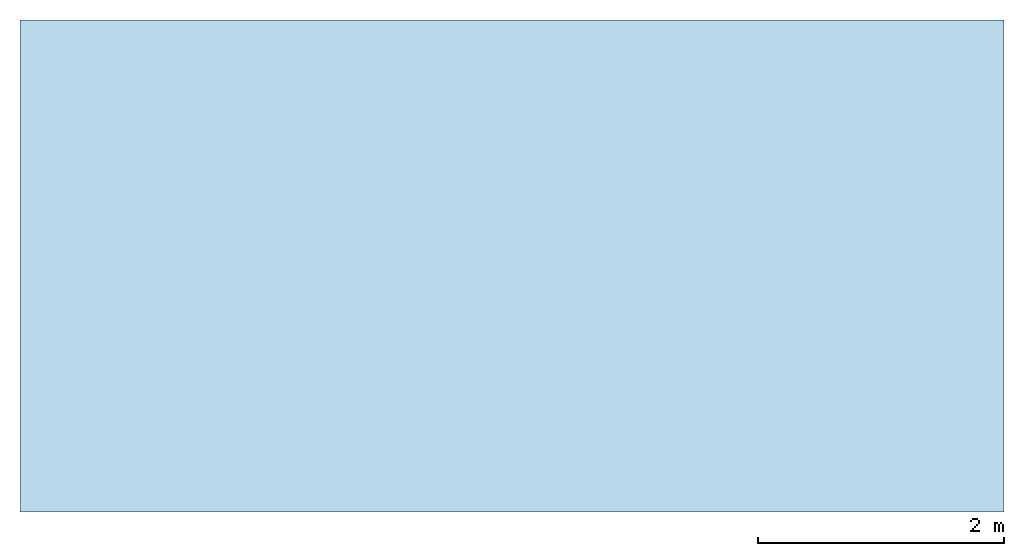
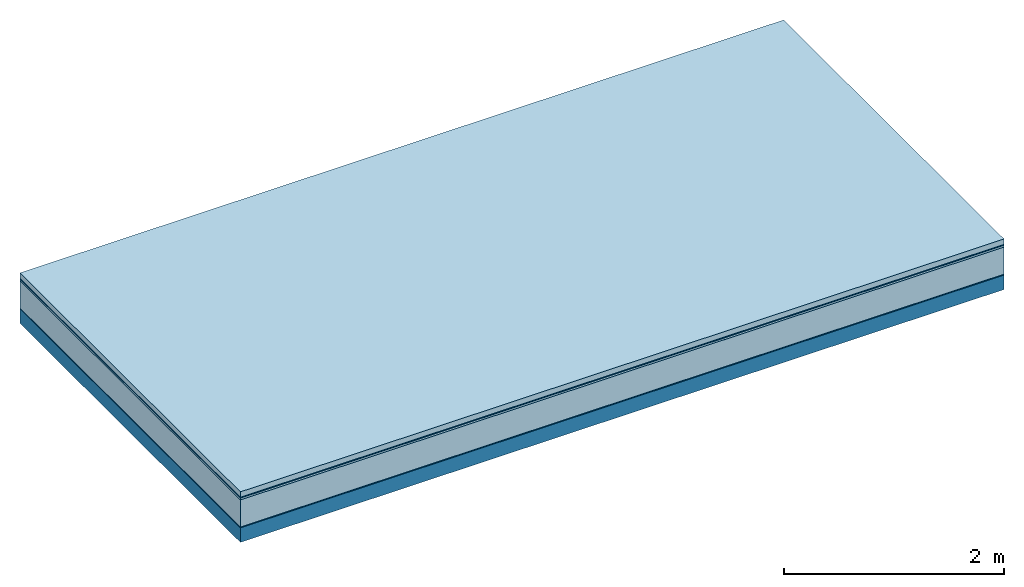
# One storey: 5 plates, 1 member, 1 element without a shape of its own.
"""IFC4 building model written with IfcOpenShell, lengths in metres."""

from ifc_helpers import new_model, si_unit, derived_unit, direction, frame, frame_2d, origin, origin_with_axes, place, context, project, spatial, rectangle, extrude, material, layer, layer_set, type_object, element, aggregate, save


model = new_model("IFC4")

# Units and contexts
plan_context = context("Plan", 3, precision=1e-05, world=origin(), true_north=direction((0.0, 1.0)))
model_context = context("Model", 3, precision=1e-05, world=origin(), true_north=direction((0.0, 1.0)))
ifc_project = project(units=[si_unit("LENGTHUNIT", "METRE"), derived_unit("SOUNDPRESSUREUNIT", [(si_unit("PRESSUREUNIT", "PASCAL", prefix="MICRO"), 0)]), si_unit("ENERGYUNIT", "JOULE", prefix="MEGA"), si_unit("MASSUNIT", "GRAM", prefix="KILO"), derived_unit("THERMALTRANSMITTANCEUNIT", [(si_unit("POWERUNIT", "WATT"), 1), (si_unit("AREAUNIT", "SQUARE_METRE"), -1), (si_unit("THERMODYNAMICTEMPERATUREUNIT", "KELVIN"), -1)]), derived_unit("AREADENSITYUNIT", [(si_unit("MASSUNIT", "GRAM", prefix="KILO"), 1), (si_unit("AREAUNIT", "SQUARE_METRE"), -1)]), derived_unit("USERDEFINED", [(si_unit("ENERGYUNIT", "JOULE", prefix="MEGA"), 1), (si_unit("AREAUNIT", "SQUARE_METRE"), -1)])], contexts=[plan_context, model_context])

# Site, building, storey
site = spatial("IfcSite", under=ifc_project)
building_placement = place(None, origin())
building = spatial("IfcBuilding", under=site, at=building_placement)
storey_placement = place(building_placement, origin())
storey = spatial("IfcBuildingStorey", under=building, at=storey_placement)

# Slab, member, plates
ifc_material_1 = material(Name="clay", Category="02.004")
ifc_layer_1 = layer(ifc_material_1, 0.06, Name="Use and protection layer 2")
ifc_material_2 = material(Name="Protective layer", Category="09.007")
ifc_layer_2 = layer(ifc_material_2, 0.01, Name="Use and protection layer 1")
ifc_material_3 = material(Name="Bituminous", Category="09.003")
ifc_layer_3 = layer(ifc_material_3, 0.02, Name="Seal")
ifc_material_4 = material(Name="Mineral wool", Category="10.008")
ifc_layer_4 = layer(ifc_material_4, 0.3, Name="Exterior insulation layer 1")
ifc_material_5 = material(Name="Vapor-permeable barrier", Category="09.006")
ifc_layer_5 = layer(ifc_material_5, 0.01, Name="layer / temporary roof")
ifc_material_6 = material(Name="no composite action")
ifc_layer_6 = layer(ifc_material_6, 0.0, Name="Bond")
ifc_layer_7 = layer(None, 0.16, Name="Support")
ifc_layer_set = layer_set([ifc_layer_1, ifc_layer_2, ifc_layer_3, ifc_layer_4, ifc_layer_5, ifc_layer_6, ifc_layer_7])
slab_type = type_object("IfcSlabType", Name="F0057", PredefinedType="NOTDEFINED", material=ifc_layer_set)
slab_placement = place(None, frame((0.0, 0.0, 0.0), z_axis=(0.0, 0.0, -1.0), x_axis=(1.0, 0.0, 0.0)))
slab = element("IfcSlab", 1, at=slab_placement, inside=storey, type_object=slab_type, material=ifc_layer_set, Name="Slab #1")
ifc_material_7 = material(Name="Solid timber panel")
member_placement = place(slab_placement, origin())
member = element("IfcMember", 2, at=member_placement, material=ifc_material_7, Name="Support", context=plan_context, shape_type="SweptSolid", body=[
    extrude(rectangle(XDim=1.0, YDim=0.16, at=frame_2d((0.5, 0.08), x_axis=(1.0, 0.0))), frame((0.0, 4.0, 0.4), z_axis=(0.0, -1.0, 0.0), x_axis=(1.0, 0.0, 0.0)), (0.0, 0.0, 1.0), 4.0),
    extrude(rectangle(XDim=1.0, YDim=0.16, at=frame_2d((0.5, 0.08), x_axis=(1.0, 0.0))), frame((1.0, 4.0, 0.4), z_axis=(0.0, -1.0, 0.0), x_axis=(1.0, 0.0, 0.0)), (0.0, 0.0, 1.0), 4.0),
    extrude(rectangle(XDim=1.0, YDim=0.16, at=frame_2d((0.5, 0.08), x_axis=(1.0, 0.0))), frame((2.0, 4.0, 0.4), z_axis=(0.0, -1.0, 0.0), x_axis=(1.0, 0.0, 0.0)), (0.0, 0.0, 1.0), 4.0),
    extrude(rectangle(XDim=1.0, YDim=0.16, at=frame_2d((0.5, 0.08), x_axis=(1.0, 0.0))), frame((3.0, 4.0, 0.4), z_axis=(0.0, -1.0, 0.0), x_axis=(1.0, 0.0, 0.0)), (0.0, 0.0, 1.0), 4.0),
    extrude(rectangle(XDim=1.0, YDim=0.16, at=frame_2d((0.5, 0.08), x_axis=(1.0, 0.0))), frame((4.0, 4.0, 0.4), z_axis=(0.0, -1.0, 0.0), x_axis=(1.0, 0.0, 0.0)), (0.0, 0.0, 1.0), 4.0),
    extrude(rectangle(XDim=1.0, YDim=0.16, at=frame_2d((0.5, 0.08), x_axis=(1.0, 0.0))), frame((5.0, 4.0, 0.4), z_axis=(0.0, -1.0, 0.0), x_axis=(1.0, 0.0, 0.0)), (0.0, 0.0, 1.0), 4.0),
    extrude(rectangle(XDim=1.0, YDim=0.16, at=frame_2d((0.5, 0.08), x_axis=(1.0, 0.0))), frame((6.0, 4.0, 0.4), z_axis=(0.0, -1.0, 0.0), x_axis=(1.0, 0.0, 0.0)), (0.0, 0.0, 1.0), 4.0),
    extrude(rectangle(XDim=1.0, YDim=0.16, at=frame_2d((0.5, 0.08), x_axis=(1.0, 0.0))), frame((7.0, 4.0, 0.4), z_axis=(0.0, -1.0, 0.0), x_axis=(1.0, 0.0, 0.0)), (0.0, 0.0, 1.0), 4.0),
])
plate_1_placement = place(slab_placement, origin())
plate_1 = element("IfcPlate", 3, at=plate_1_placement, material=ifc_material_1, Name="Use and protection layer 2", context=plan_context, shape_type="SweptSolid", body=[
    extrude(rectangle(XDim=8.0, YDim=4.0, at=frame_2d((4.0, 2.0), x_axis=(1.0, 0.0))), origin_with_axes(), (0.0, 0.0, 1.0), 0.06),
])
plate_2_placement = place(slab_placement, origin())
plate_2 = element("IfcPlate", 4, at=plate_2_placement, material=ifc_material_2, Name="Use and protection layer 1", context=plan_context, shape_type="SweptSolid", body=[
    extrude(rectangle(XDim=8.0, YDim=4.0, at=frame_2d((4.0, 2.0), x_axis=(1.0, 0.0))), frame((0.0, 0.0, 0.06), z_axis=(0.0, 0.0, 1.0), x_axis=(1.0, 0.0, 0.0)), (0.0, 0.0, 1.0), 0.01),
])
plate_3_placement = place(slab_placement, origin())
plate_3 = element("IfcPlate", 5, at=plate_3_placement, material=ifc_material_3, Name="Seal", context=plan_context, shape_type="SweptSolid", body=[
    extrude(rectangle(XDim=8.0, YDim=4.0, at=frame_2d((4.0, 2.0), x_axis=(1.0, 0.0))), frame((0.0, 0.0, 0.07), z_axis=(0.0, 0.0, 1.0), x_axis=(1.0, 0.0, 0.0)), (0.0, 0.0, 1.0), 0.02),
])
plate_4_placement = place(slab_placement, origin())
plate_4 = element("IfcPlate", 6, at=plate_4_placement, material=ifc_material_4, Name="Exterior insulation layer 1", context=plan_context, shape_type="SweptSolid", body=[
    extrude(rectangle(XDim=8.0, YDim=4.0, at=frame_2d((4.0, 2.0), x_axis=(1.0, 0.0))), frame((0.0, 0.0, 0.09), z_axis=(0.0, 0.0, 1.0), x_axis=(1.0, 0.0, 0.0)), (0.0, 0.0, 1.0), 0.3),
])
plate_5_placement = place(slab_placement, origin())
plate_5 = element("IfcPlate", 7, at=plate_5_placement, material=ifc_material_5, Name="layer / temporary roof", context=plan_context, shape_type="SweptSolid", body=[
    extrude(rectangle(XDim=8.0, YDim=4.0, at=frame_2d((4.0, 2.0), x_axis=(1.0, 0.0))), frame((0.0, 0.0, 0.39), z_axis=(0.0, 0.0, 1.0), x_axis=(1.0, 0.0, 0.0)), (0.0, 0.0, 1.0), 0.01),
])
aggregate(slab, [plate_1, plate_2, plate_3, plate_4, plate_5, member])

save(model, "model.ifc")
